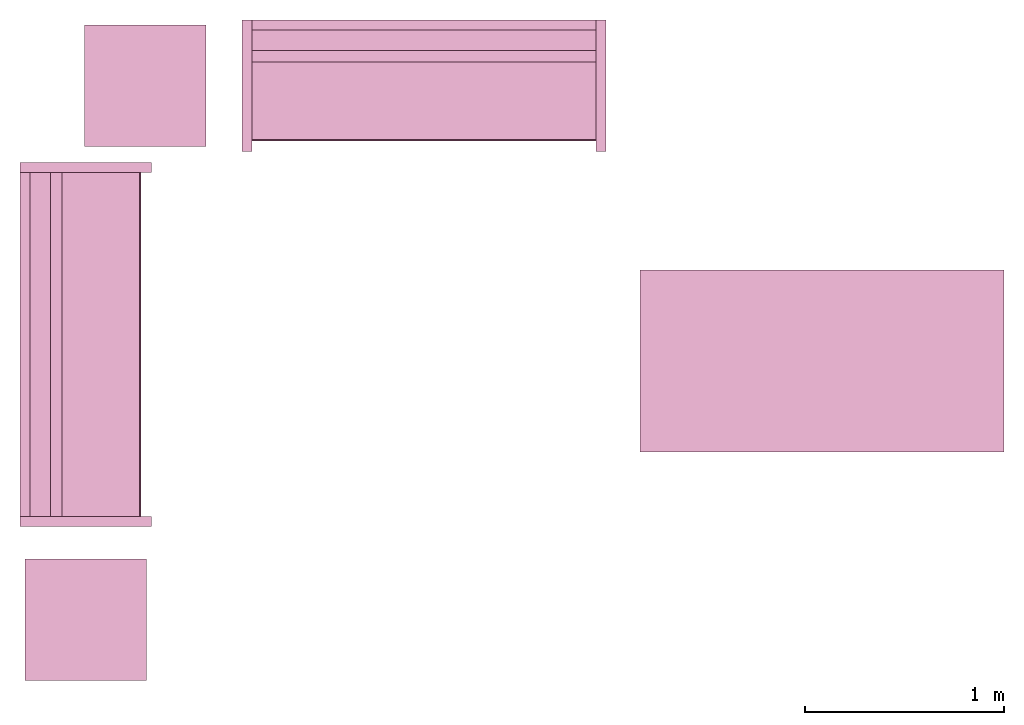
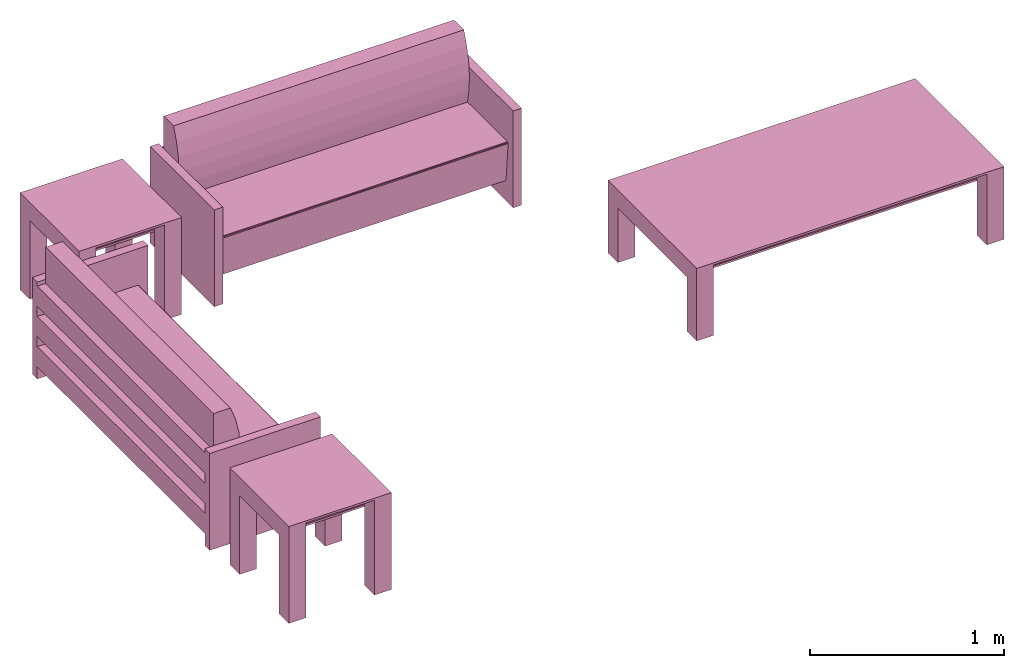
# One storey: 5 furnishings.
"""IFC2X3 building model written with IfcOpenShell, lengths in metres."""

from ifc_helpers import new_model, entity, si_unit, converted_unit, frame, origin, origin_with_axes, origin_2d_with_axis, place, context, project, spatial, polyline, rectangle, outline, extrude, face_set, surface_model, source, transform, mapped, type_object, type_shapes, element, save


model = new_model("IFC2X3")

# Units and contexts
model_context = context("Model", 3, precision=1e-09, world=origin())
plan_context = context("Plan", 3, precision=1e-09, world=origin())
ifc_project = project(units=[si_unit("LENGTHUNIT", "METRE"), si_unit("AREAUNIT", "SQUARE_METRE"), si_unit("VOLUMEUNIT", "CUBIC_METRE"), converted_unit("PLANEANGLEUNIT", "DEGREE", entity("IfcRatioMeasure", 0.0174532925199433), si_unit("PLANEANGLEUNIT", "RADIAN"), dimensions=[0, 0, 0, 0, 0, 0, 0]), si_unit("TIMEUNIT", "SECOND")], contexts=[model_context, plan_context])

# Site, building, storey, space
site_placement = place(None, origin_with_axes())
site = spatial("IfcSite", under=ifc_project, at=site_placement, CompositionType="ELEMENT")
building_placement = place(None, origin_with_axes())
building = spatial("IfcBuilding", under=site, at=building_placement, CompositionType="ELEMENT")
storey_placement = place(None, origin_with_axes())
storey = spatial("IfcBuildingStorey", under=building, at=storey_placement, Name="Level 1", CompositionType="ELEMENT", Elevation=0.0)
space_placement = place(None, origin_with_axes())
space = spatial("IfcSpace", under=storey, at=space_placement, CompositionType="ELEMENT", InteriorOrExteriorSpace="INTERNAL")

# Furnishings
furniture_type_1 = type_object("IfcFurnitureType", Name="1830mm", AssemblyPlace="NOTDEFINED")
shared_shape_1 = source(origin(), model_context, "Body", "SurfaceModel", [
    surface_model("IfcFaceBasedSurfaceModel", [(0.0507999999999982, 0.609599999999997, 0.5842), (0.0507999999999983, 0.660399999999998, 0.5842), (0.0507999999999983, 0.660399999999998, 0.4572), (0.0507999999999982, 0.609599999999997, 0.4572), (0.0507999999999982, 0.609599999999998, 0.3937), (0.0507999999999983, 0.660399999999998, 0.3937), (0.0507999999999983, 0.660399999999998, 0.2667), (0.0507999999999982, 0.609599999999998, 0.2667), (0.0507999999999982, 0.609600000000004, 0.2032), (0.0507999999999983, 0.660399999999998, 0.2032), (0.0507999999999983, 0.660399999999998, 0.0762), (0.0507999999999982, 0.609600000000004, 0.0762), (1.77919999999999, 0.609599999999994, 0.5842), (1.77919999999999, 0.609599999999994, 0.4572), (1.77919999999999, 0.660399999999995, 0.4572), (1.77919999999999, 0.660399999999995, 0.5842), (1.77919999999999, 0.609599999999995, 0.3937), (1.77919999999999, 0.609599999999995, 0.2667), (1.77919999999999, 0.660399999999995, 0.2667), (1.77919999999999, 0.660399999999995, 0.3937), (1.77919999999999, 0.609600000000001, 0.2032), (1.77919999999999, 0.609600000000001, 0.0762), (1.77919999999999, 0.660399999999995, 0.0762), (1.77919999999999, 0.660399999999995, 0.2032), (0.0507999999999978, 0.470222395089521, 0.380999999999998), (0.0507999999999978, 0.454401348887885, 0.467831162756508), (0.0507999999999978, 0.450300415835913, 0.555996567971167), (0.0507999999999978, 0.457992845249543, 0.643921438504357), (0.0507999999999978, 0.477341237862486, 0.730035293556011), (0.0507999999999979, 0.507999999999975, 0.812799999999995), (0.0507999999999981, 0.609599999999998, 0.812799999999998), (0.0507999999999981, 0.609599999999998, 0.127966546684697), (0.0507999999999971, 0.0729375586579064, 0.127966546684697), (0.0507999999999971, 0.0520079452978146, 0.367193122067106), (0.0507999999999971, 0.0526336053189921, 0.372382281209352), (0.0507999999999971, 0.0552961957860913, 0.37687999563672), (0.0507999999999971, 0.0595447350023739, 0.379924455784818), (0.0507999999999971, 0.0646596179635799, 0.381000000000001), (1.77919999999998, 0.470222395089517, 0.381000000000001), (1.77919999999998, 0.0646596179635769, 0.381000000000001), (1.77919999999998, 0.059544735002371, 0.379924455784818), (1.77919999999998, 0.0552961957860883, 0.37687999563672), (1.77919999999998, 0.0526336053189891, 0.372382281209352), (1.77919999999998, 0.0520079452978117, 0.367193122067106), (1.77919999999998, 0.0729375586579034, 0.127966546684697), (1.77919999999998, 0.609599999999995, 0.127966546684697), (1.77919999999998, 0.609599999999995, 0.812799999999998), (1.77919999999998, 0.507999999999972, 0.812799999999995), (1.77919999999998, 0.477341237862483, 0.730035293556011), (1.77919999999998, 0.45799284524954, 0.643921438504357), (1.77919999999998, 0.45030041583591, 0.555996567971167), (1.77919999999998, 0.454401348887882, 0.467831162756508), (0.050799984484911, 0.0539648979902268, 0.374631136655807), (1.77919995784759, 0.0539648979902268, 0.374631136655807), (0.050799984484911, 0.0523207746446133, 0.369787722826004), (1.77919995784759, 0.0523207746446133, 0.369787722826004), (1.77919995784759, 0.0621021725237369, 0.380462229251862), (0.050799984484911, 0.0621788389980793, 0.380478352308273), (1.77919995784759, 0.0574204623699188, 0.378402233123779), (0.050799984484911, 0.0574204623699188, 0.378402233123779), (0.0507999999999971, 0.660399999999997, 0.6096), (0.0507999999999971, 0.0, 0.6096), (0.0, 0.0, 0.6096), (0.0, 0.660399999999997, 0.6096), (1.83, 0.660400000000039, 0.6096), (1.83, 0.0, 0.6096), (1.77919999999997, 0.0, 0.6096), (1.77919999999997, 0.660400000000039, 0.6096), (0.0507999999999971, 0.660399999999997, 0.0), (0.0507999999999971, 0.0, 0.0), (0.0, 0.0, 0.0), (0.0, 0.660399999999997, 0.0), (1.83, 0.660400000000039, 0.0), (1.83, 0.0, 0.0), (1.77919999999997, 0.0, 0.0), (1.77919999999997, 0.660400000000039, 0.0)], [face_set([[[0, 1, 2, 3]], [[4, 5, 6, 7]], [[8, 9, 10, 11]], [[12, 13, 14, 15]], [[16, 17, 18, 19]], [[20, 21, 22, 23]], [[1, 15, 12, 0]], [[2, 14, 15, 1]], [[3, 2, 14, 13]], [[0, 3, 13, 12]], [[5, 19, 16, 4]], [[6, 18, 19, 5]], [[7, 6, 18, 17]], [[4, 7, 17, 16]], [[9, 23, 20, 8]], [[10, 22, 23, 9]], [[11, 10, 22, 21]], [[8, 11, 21, 20]]]), face_set([[[24, 25, 26, 27, 28, 29, 30, 31, 32, 33, 34, 35, 36, 37]], [[38, 39, 40, 41, 42, 43, 44, 45, 46, 47, 48, 49, 50, 51]], [[24, 25, 51, 38]], [[25, 26, 50, 51]], [[49, 50, 26, 27]], [[27, 28, 48, 49]], [[28, 29, 47, 48]], [[30, 46, 47, 29]], [[31, 30, 46, 45]], [[32, 31, 45, 44]], [[33, 32, 44, 43]], [[41, 35, 52, 53]], [[54, 55, 42, 34]], [[33, 43, 55, 54]], [[34, 42, 53, 52]], [[39, 56, 57]], [[35, 41, 58, 59]], [[56, 40, 36]], [[57, 37, 39]], [[57, 56, 36]], [[40, 36, 59, 58]], [[24, 38, 39, 37]]]), face_set([[[60, 61, 62, 63]], [[64, 65, 66, 67]], [[68, 69, 70, 71]], [[72, 73, 74, 75]], [[63, 60, 68, 71]], [[62, 63, 71, 70]], [[61, 62, 70, 69]], [[60, 68, 69, 61]], [[67, 64, 72, 75]], [[66, 74, 75, 67]], [[65, 66, 74, 73]], [[64, 65, 73, 72]]])]),
])
type_shapes(furniture_type_1, [shared_shape_1])
for number, where, z_axis, x_axis, name in (
    (1, (1.23109931406676, -16.2703826647373, 0.0), (0.0, 0.0, 1.0), (0.0, 1.0, 0.0), "M_Sofa:1830mm:1830mm"),
    (2, (1.68589931406676, -14.3855826647373, 0.0), (0.0, 0.0, 1.0), (1.0, 0.0, 0.0), "M_Sofa:1830mm:1830mm"),
):
    element("IfcFurnishingElement", number, at=place(None, frame(where, z_axis=z_axis, x_axis=x_axis)), inside=space, type_object=furniture_type_1, Name=name, context=model_context, shape_type="MappedRepresentation", body=[
        mapped(shared_shape_1, transform((0.0, 0.0, 0.0), scale=1.0)),
    ])
furniture_type_2 = type_object("IfcFurnitureType", Name="0610 x 0610 x 0610mm", AssemblyPlace="NOTDEFINED")
shared_shape_2 = source(origin(), model_context, "Body", "SweptSolid", [
    extrude(rectangle(XDim=0.406799999999999, YDim=0.406799999999999, at=origin_2d_with_axis()), frame((0.0182657666726316, 0.0952110778022263, 0.4957), z_axis=(0.0, 0.0, 1.0), x_axis=(-1.0, 0.0, 0.0)), (0.0, 0.0, 1.0), 0.0127),
    extrude(outline(polyline([(-0.273249999999994, -0.305), (0.324049999999978, -0.305), (0.324049999999978, 0.304999999999998), (-0.273249999999993, 0.304999999999999), (-0.273249999999993, 0.203400000000001), (0.222450000000009, 0.203400000000001), (0.222450000000009, -0.2034), (-0.273249999999994, -0.2034), (-0.273249999999994, -0.305)])), frame((0.221665766672633, 0.0952110778022354, 0.273249999999992), z_axis=(1.0, 0.0, 0.0), x_axis=(0.0, 0.0, 1.0)), (0.0, 0.0, 1.0), 0.1016),
    extrude(outline(polyline([(-0.305000000000004, -0.324050000000025), (0.304999999999994, -0.324050000000025), (0.304999999999994, 0.273250000000011), (0.203400000000004, 0.273250000000011), (0.203400000000004, -0.222449999999996), (-0.203399999999995, -0.222449999999996), (-0.203399999999995, 0.273250000000011), (-0.305000000000004, 0.273250000000011), (-0.305000000000004, -0.324050000000025)])), frame((-0.286734233327367, 0.0952110778022256, 0.273250000000008), z_axis=(1.0, 0.0, 0.0), x_axis=(0.0, -1.0, 0.0)), (0.0, 0.0, 1.0), 0.1016),
    extrude(rectangle(XDim=0.406799999999999, YDim=0.406799999999999, at=origin_2d_with_axis()), frame((0.0182657666726316, 0.0952110778022259, 0.5973), z_axis=(0.0, 0.0, 1.0), x_axis=(-1.0, 0.0, 0.0)), (0.0, 0.0, 1.0), 0.0127),
    extrude(outline(polyline([(-0.305, -0.305000000000023), (0.305, -0.305000000000023), (0.305, 0.305000000000023), (-0.305, 0.305000000000023), (-0.305, -0.305000000000023)]), holes=[polyline([(-0.203399999999998, -0.203399999999975), (-0.203399999999998, 0.203400000000025), (0.203400000000001, 0.203400000000025), (0.203400000000001, -0.203399999999975), (-0.203399999999998, -0.203399999999975)])]), frame((0.0182657666726332, 0.0952110778022508, 0.5973), z_axis=(0.0, 0.0, 1.0), x_axis=(-1.0, 0.0, 0.0)), (0.0, 0.0, 1.0), 0.0127),
])
type_shapes(furniture_type_2, [shared_shape_2])
for number, where, z_axis, x_axis, name in (
    (3, (0.919165080739398, -16.6431715869351, 0.0), (0.0, 0.0, 1.0), (-1.0, 0.0, 0.0), "M_Table-Coffee:0610 x 0610 x 0610mm:0610 x 0610 x 0610mm"),
    (4, (1.21916508073938, -13.9601715869351, 0.0), (0.0, 0.0, 1.0), (-1.0, 0.0, 0.0), "M_Table-Coffee:0610 x 0610 x 0610mm:0610 x 0610 x 0610mm"),
):
    element("IfcFurnishingElement", number, at=place(None, frame(where, z_axis=z_axis, x_axis=x_axis)), inside=space, type_object=furniture_type_2, Name=name, context=model_context, shape_type="MappedRepresentation", body=[
        mapped(shared_shape_2, transform((0.0, 0.0, 0.0), scale=1.0)),
    ])
furniture_type_3 = type_object("IfcFurnitureType", Name="0915 x 1830 x 0457mm", AssemblyPlace="NOTDEFINED")
shared_shape_3 = source(origin(), model_context, "Body", "SweptSolid", [
    extrude(rectangle(XDim=1.6268, YDim=0.711799999999999, at=origin_2d_with_axis()), frame((0.0182657666726317, 0.0952110778022268, 0.3427), z_axis=(0.0, 0.0, 1.0), x_axis=(-1.0, 0.0, 0.0)), (0.0, 0.0, 1.0), 0.0127),
    extrude(outline(polyline([(-0.196749999999994, -0.4575), (0.247549999999978, -0.4575), (0.247549999999978, 0.457499999999999), (-0.196749999999993, 0.457499999999999), (-0.196749999999993, 0.355900000000002), (0.145950000000009, 0.355900000000001), (0.145950000000009, -0.3559), (-0.196749999999994, -0.3559), (-0.196749999999994, -0.4575)])), frame((0.831665766672632, 0.0952110778022354, 0.196749999999991), z_axis=(1.0, 0.0, 0.0), x_axis=(0.0, 0.0, 1.0)), (0.0, 0.0, 1.0), 0.1016),
    extrude(outline(polyline([(-0.457500000000004, -0.247550000000026), (0.457499999999994, -0.247550000000026), (0.457499999999994, 0.196750000000011), (0.355900000000004, 0.196750000000011), (0.355900000000004, -0.145949999999996), (-0.355899999999994, -0.145949999999996), (-0.355899999999994, 0.196750000000011), (-0.457500000000004, 0.196750000000011), (-0.457500000000004, -0.247550000000026)])), frame((-0.896734233327367, 0.0952110778022256, 0.196750000000009), z_axis=(1.0, 0.0, 0.0), x_axis=(0.0, -1.0, 0.0)), (0.0, 0.0, 1.0), 0.1016),
    extrude(rectangle(XDim=1.6268, YDim=0.711799999999999, at=origin_2d_with_axis()), frame((0.0182657666726317, 0.0952110778022265, 0.4443), z_axis=(0.0, 0.0, 1.0), x_axis=(-1.0, 0.0, 0.0)), (0.0, 0.0, 1.0), 0.0127),
    extrude(outline(polyline([(-0.915, -0.457500000000023), (0.915, -0.457500000000023), (0.915, 0.457500000000023), (-0.915, 0.457500000000023), (-0.915, -0.457500000000023)]), holes=[polyline([(-0.813399999999998, -0.355899999999975), (-0.813399999999998, 0.355900000000025), (0.813400000000001, 0.355900000000024), (0.813400000000001, -0.355899999999975), (-0.813399999999998, -0.355899999999975)])]), frame((0.0182657666726332, 0.0952110778022514, 0.4443), z_axis=(0.0, 0.0, 1.0), x_axis=(-1.0, 0.0, 0.0)), (0.0, 0.0, 1.0), 0.0127),
])
type_shapes(furniture_type_3, [shared_shape_3])
furnishing_placement = place(space_placement, frame((4.61916508073939, -15.3431715869351, 0.0), z_axis=(0.0, 0.0, 1.0), x_axis=(-1.0, 0.0, 0.0)))
element("IfcFurnishingElement", 5, at=furnishing_placement, inside=space, type_object=furniture_type_3, Name="M_Table-Coffee:0915 x 1830 x 0457mm:0915 x 1830 x 0457mm", context=model_context, shape_type="MappedRepresentation", body=[
    mapped(shared_shape_3, transform((0.0, 0.0, 0.0), scale=1.0)),
])

save(model, "model.ifc")
